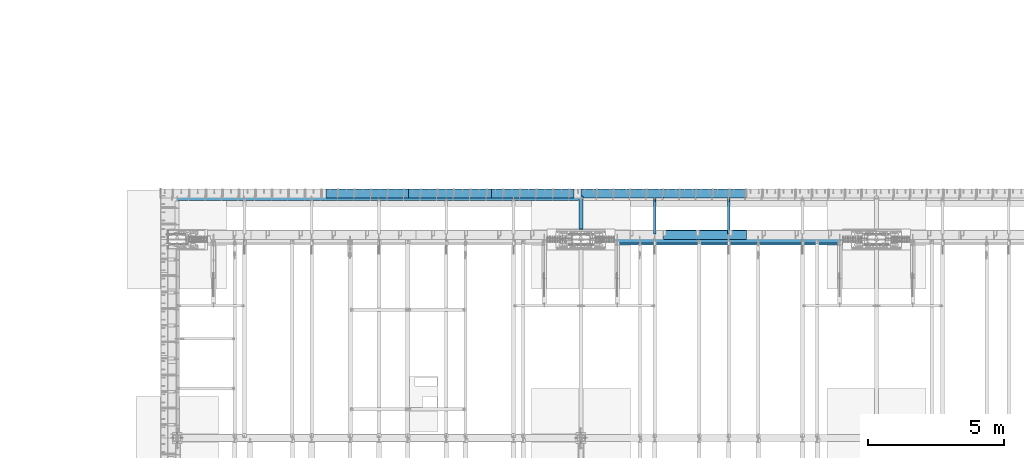
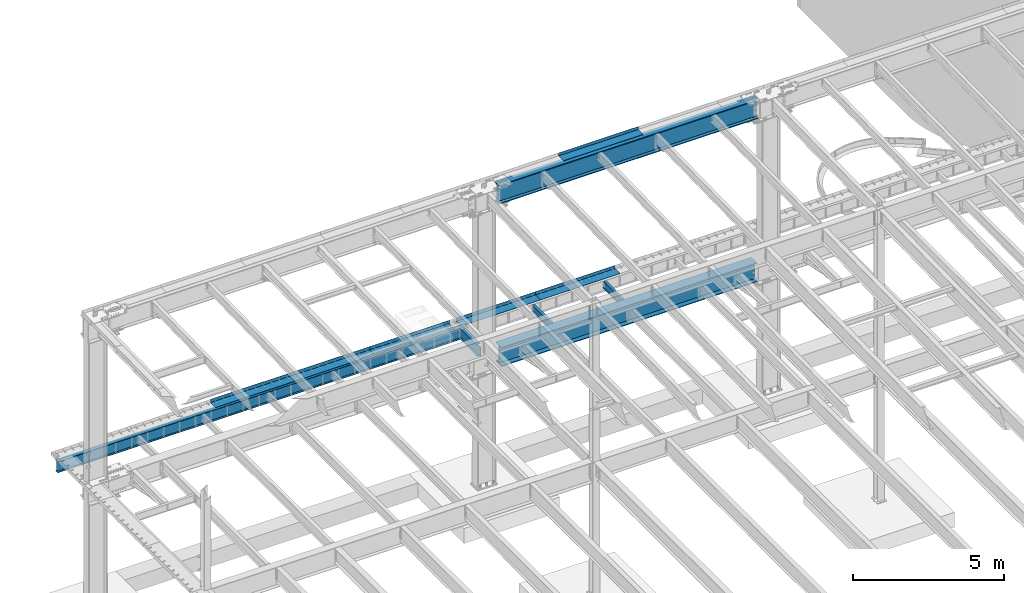
# One storey, part 1130 of 1763: 12 beams, 7 elements without a shape of their own.
"""IFC2X3 building model written with IfcOpenShell, lengths in millimetres."""

from ifc_helpers import new_model, si_unit, frame, origin_with_axes, place, context, subcontext, project, spatial, faceted_brep, material, type_object, element, aggregate, save


model = new_model("IFC2X3")

# Units and contexts
model_context = context("Model", 3, precision=1e-05, world=origin_with_axes())
body_context = subcontext(model_context, "Body", "Model", "MODEL_VIEW")
ifc_project = project(units=[si_unit("LENGTHUNIT", "METRE", prefix="MILLI"), si_unit("AREAUNIT", "SQUARE_METRE"), si_unit("VOLUMEUNIT", "CUBIC_METRE"), si_unit("MASSUNIT", "GRAM", prefix="KILO"), si_unit("TIMEUNIT", "SECOND"), si_unit("PLANEANGLEUNIT", "RADIAN"), si_unit("SOLIDANGLEUNIT", "STERADIAN"), si_unit("THERMODYNAMICTEMPERATUREUNIT", "DEGREE_CELSIUS"), si_unit("LUMINOUSINTENSITYUNIT", "LUMEN")], contexts=[model_context])

# Site, building, storey
site_placement = place(None, origin_with_axes())
site = spatial("IfcSite", under=ifc_project, at=site_placement, CompositionType="ELEMENT")
building_placement = place(site_placement, origin_with_axes())
building = spatial("IfcBuilding", under=site, at=building_placement, Name="Undefined", CompositionType="ELEMENT")
storey_placement = place(building_placement, origin_with_axes())
storey = spatial("IfcBuildingStorey", under=building, at=storey_placement, Name="Undefined", CompositionType="ELEMENT", Elevation=0.0)

# Assembly, beam
assembly_1_placement = place(storey_placement, origin_with_axes())
assembly_1 = element("IfcElementAssembly", 1, at=assembly_1_placement, inside=storey, Name="BEAM", AssemblyPlace="NOTDEFINED", PredefinedType="RIGID_FRAME")
ifc_material_1 = material(Name="STEEL/A36")
beam_type_1 = type_object("IfcBeamType", PredefinedType="NOTDEFINED")
beam_1_placement = place(assembly_1_placement, frame((-67915.8617736983, 52133.5000002128, 11752.2624917654), z_axis=(-1.0, 0.0, 0.0), x_axis=(0.0, 1.0, 0.0)))
beam_1 = element("IfcBeam", 2, at=beam_1_placement, type_object=beam_type_1, material=ifc_material_1, Name="BENT_PLATE", context=body_context, shape_type="Brep", body=[
    faceted_brep([(0.0, -4.76249999999982, -1524.0), (0.0, -4.76249999999982, 1524.0), (0.0, 4.76249999999982, 1524.0), (0.0, 4.76249999999982, -1524.0), (336.549987792969, 4.76250000000073, 1524.0), (336.549987792969, 4.76250000000073, -1524.0), (327.024987792975, -4.76250000000073, -1524.0), (327.024987792967, -4.76250000000073, 1524.00000000001), (336.549987792969, -122.237499999999, 1524.0), (336.549987792969, -122.237499999999, -1524.0), (327.024987792975, -122.237499999999, 1524.0), (327.024987792975, -122.237499999999, -1524.0)], [[[0, 1, 2, 3]], [[3, 2, 4, 5]], [[1, 0, 6, 7]], [[5, 4, 8, 9]], [[4, 2, 1, 7, 10, 8]], [[7, 6, 11, 10]], [[6, 0, 3, 5, 9, 11]], [[10, 11, 9, 8]]]),
])

# Assembly, beams
assembly_2_placement = place(storey_placement, origin_with_axes())
assembly_2 = element("IfcElementAssembly", 3, at=assembly_2_placement, inside=storey, Name="BEAM", AssemblyPlace="NOTDEFINED", PredefinedType="RIGID_FRAME")
beam_type_2 = type_object("IfcBeamType", PredefinedType="NOTDEFINED")
beam_2_placement = place(assembly_2_placement, frame((-67919.0372736984, 53657.5, 5199.0625), z_axis=(1.0, 0.0, 0.0), x_axis=(0.0, 1.0, 0.0)))
beam_2 = element("IfcBeam", 4, at=beam_2_placement, type_object=beam_type_2, material=ifc_material_1, Name="BENT PLATE", context=body_context, shape_type="Brep", body=[
    faceted_brep([(0.0, -4.76249999999982, -1524.0), (0.0, -4.76249999999982, 1524.0), (0.0, 4.76249999999982, 1524.0), (0.0, 4.76249999999982, -1524.0), (327.024987792967, 4.76250000000073, 1524.0), (327.025018310553, 4.76249999999982, -1524.0), (336.550018310547, -4.76249999999982, -1524.0), (336.550018310547, -4.76249999999982, 1524.0), (327.025018310553, 134.937496948242, 1524.0), (327.025018310553, 134.937496948242, -1524.0), (336.550018310547, 134.937496948242, 1524.0), (336.550018310547, 134.937496948242, -1524.0)], [[[0, 1, 2, 3]], [[3, 2, 4, 5]], [[1, 0, 6, 7]], [[5, 4, 8, 9]], [[4, 2, 1, 7, 10, 8]], [[7, 6, 11, 10]], [[6, 0, 3, 5, 9, 11]], [[10, 11, 9, 8]]]),
])
beam_3_placement = place(assembly_2_placement, frame((-70967.0372736984, 53657.5, 5199.0625), z_axis=(1.0, 0.0, 0.0), x_axis=(0.0, 1.0, 0.0)))
beam_3 = element("IfcBeam", 5, at=beam_3_placement, type_object=beam_type_2, material=ifc_material_1, Name="BENT PLATE", context=body_context, shape_type="Brep", body=[
    faceted_brep([(0.0, -4.76249999999982, -1524.0), (0.0, -4.76249999999982, 1524.0), (0.0, 4.76249999999982, 1524.0), (0.0, 4.76249999999982, -1524.0), (327.024987792967, 4.76250000000073, 1524.0), (327.025018310553, 4.76249999999982, -1524.0), (336.550018310547, -4.76249999999982, -1524.0), (336.550018310547, -4.76249999999982, 1524.0), (327.025018310553, 134.937496948242, 1524.0), (327.025018310553, 134.937496948242, -1524.0), (336.550018310547, 134.937496948242, 1524.0), (336.550018310547, 134.937496948242, -1524.0)], [[[0, 1, 2, 3]], [[3, 2, 4, 5]], [[1, 0, 6, 7]], [[5, 4, 8, 9]], [[4, 2, 1, 7, 10, 8]], [[7, 6, 11, 10]], [[6, 0, 3, 5, 9, 11]], [[10, 11, 9, 8]]]),
])
aggregate(assembly_2, [beam_2, beam_3])

assembly_3_placement = place(storey_placement, origin_with_axes())
assembly_3 = element("IfcElementAssembly", 6, at=assembly_3_placement, inside=storey, Name="BEAM", AssemblyPlace="NOTDEFINED", PredefinedType="RIGID_FRAME")
beam_4_placement = place(assembly_3_placement, frame((-74269.0372736984, 53657.5, 5199.0625), z_axis=(1.0, 0.0, 0.0), x_axis=(0.0, 1.0, 0.0)))
beam_4 = element("IfcBeam", 7, at=beam_4_placement, type_object=beam_type_2, material=ifc_material_1, Name="BENT PLATE", context=body_context, shape_type="Brep", body=[
    faceted_brep([(0.0, -4.76249999999982, -1524.0), (0.0, -4.76249999999982, 1524.0), (0.0, 4.76249999999982, 1524.0), (0.0, 4.76249999999982, -1524.0), (327.024987792967, 4.76250000000073, 1524.0), (327.025018310553, 4.76249999999982, -1524.0), (336.550018310547, -4.76249999999982, -1524.0), (336.550018310547, -4.76249999999982, 1524.0), (327.025018310553, 134.937496948242, 1524.0), (327.025018310553, 134.937496948242, -1524.0), (336.550018310547, 134.937496948242, 1524.0), (336.550018310547, 134.937496948242, -1524.0)], [[[0, 1, 2, 3]], [[3, 2, 4, 5]], [[1, 0, 6, 7]], [[5, 4, 8, 9]], [[4, 2, 1, 7, 10, 8]], [[7, 6, 11, 10]], [[6, 0, 3, 5, 9, 11]], [[10, 11, 9, 8]]]),
])
beam_5_placement = place(assembly_3_placement, frame((-77317.0372736984, 53657.5, 5199.0625), z_axis=(1.0, 0.0, 0.0), x_axis=(0.0, 1.0, 0.0)))
beam_5 = element("IfcBeam", 8, at=beam_5_placement, type_object=beam_type_2, material=ifc_material_1, Name="BENT PLATE", context=body_context, shape_type="Brep", body=[
    faceted_brep([(0.0, -4.76249999999982, -1524.0), (0.0, -4.76249999999982, 1524.0), (0.0, 4.76249999999982, 1524.0), (0.0, 4.76249999999982, -1524.0), (327.024987792967, 4.76250000000073, 1524.0), (327.025018310553, 4.76249999999982, -1524.0), (336.550018310547, -4.76249999999982, -1524.0), (336.550018310547, -4.76249999999982, 1524.0), (327.025018310553, 134.937496948242, 1524.0), (327.025018310553, 134.937496948242, -1524.0), (336.550018310547, 134.937496948242, 1524.0), (336.550018310547, 134.937496948242, -1524.0)], [[[0, 1, 2, 3]], [[3, 2, 4, 5]], [[1, 0, 6, 7]], [[5, 4, 8, 9]], [[4, 2, 1, 7, 10, 8]], [[7, 6, 11, 10]], [[6, 0, 3, 5, 9, 11]], [[10, 11, 9, 8]]]),
])
beam_6_placement = place(assembly_3_placement, frame((-80365.0372736984, 53657.5, 5199.0625), z_axis=(1.0, 0.0, 0.0), x_axis=(0.0, 1.0, 0.0)))
beam_6 = element("IfcBeam", 9, at=beam_6_placement, type_object=beam_type_2, material=ifc_material_1, Name="BENT PLATE", context=body_context, shape_type="Brep", body=[
    faceted_brep([(0.0, -4.76249999999982, -1524.0), (0.0, -4.76249999999982, 1524.0), (0.0, 4.76249999999982, 1524.0), (0.0, 4.76249999999982, -1524.0), (327.024987792967, 4.76250000000073, 1524.0), (327.025018310553, 4.76249999999982, -1524.0), (336.550018310547, -4.76249999999982, -1524.0), (336.550018310547, -4.76249999999982, 1524.0), (327.025018310553, 134.937496948242, 1524.0), (327.025018310553, 134.937496948242, -1524.0), (336.550018310547, 134.937496948242, 1524.0), (336.550018310547, 134.937496948242, -1524.0)], [[[0, 1, 2, 3]], [[3, 2, 4, 5]], [[1, 0, 6, 7]], [[5, 4, 8, 9]], [[4, 2, 1, 7, 10, 8]], [[7, 6, 11, 10]], [[6, 0, 3, 5, 9, 11]], [[10, 11, 9, 8]]]),
])

# Assembly, beam
assembly_4_placement = place(storey_placement, origin_with_axes())
assembly_4 = element("IfcElementAssembly", 10, at=assembly_4_placement, inside=storey, Name="BEAM", AssemblyPlace="NOTDEFINED", PredefinedType="RIGID_FRAME")
ifc_material_2 = material(Name="STEEL/A992")
beam_type_3 = type_object("IfcBeamType", Name="W12X16", PredefinedType="NOTDEFINED")
beam_7_placement = place(assembly_4_placement, frame((-67042.7372736984, 52120.8, 5041.9), z_axis=(0.0, 0.0, 1.0), x_axis=(0.0, 1.0, 0.0)))
beam_7 = element("IfcBeam", 11, at=beam_7_placement, type_object=beam_type_3, material=ifc_material_2, Name="BEAM", ObjectType="W12X16", context=body_context, shape_type="Brep", body=[
    faceted_brep([(20.6374999999971, -3.17500000000291, -114.3), (20.6374999999971, 3.17500000000291, -114.3), (192.087500190733, 3.17500000000291, -114.3), (192.087500190733, -3.17500000000291, -114.3), (196.94757970878, 3.17500000000291, -115.266729922588), (196.94757970878, -3.17500000000291, -115.266729922588), (201.067756176933, 3.17500000000291, -118.019743823066), (201.067756176933, -3.17500000000291, -118.019743823066), (203.820770077407, 3.17500000000291, -122.13992029122), (203.820770077407, -3.17500000000291, -122.13992029122), (204.787499999999, -3.17500000000291, -126.999999809265), (204.787499999999, 3.17500000000291, -126.999999809265), (204.787499999999, 3.17500000000291, -146.05), (204.787499999999, 50.8000000000029, -146.05), (204.787499999999, 50.8000000000029, -152.4), (204.787499999999, -50.8000000000029, -152.4), (204.787499999999, -50.8000000000029, -146.05), (204.787499999999, -3.17500000000291, -146.05), (1431.13125000001, 50.8000000000029, 146.05), (1431.13125000001, 3.17500000000291, 146.05), (204.787499999999, 3.17500000000291, 146.05), (204.787499999999, 50.8000000000029, 146.05), (192.087500190733, -3.17500000000291, 114.3), (192.087500190733, 3.17500000000291, 114.3), (20.6374999999971, 3.17500000000291, 114.3), (20.6374999999971, -3.17500000000291, 114.3), (196.94757970878, -3.17500000000291, 115.266729922588), (196.94757970878, 3.17500000000291, 115.266729922588), (201.067756176933, -3.17500000000291, 118.019743823066), (201.067756176933, 3.17500000000291, 118.019743823066), (203.820770077407, -3.17500000000291, 122.13992029122), (203.820770077407, 3.17500000000291, 122.13992029122), (204.787499999999, -3.17500000000291, 126.999999809265), (204.787499999999, 3.17500000000291, 126.999999809265), (1431.13125000001, -50.8000000000029, 152.4), (1431.13125000001, 50.8000000000029, 152.4), (204.787499999999, 50.8000000000029, 152.4), (204.787499999999, -50.8000000000029, 152.4), (1431.13125000001, -50.8000000000029, 146.05), (204.787499999999, -50.8000000000029, 146.05), (1431.13125000001, -3.17500000000291, 146.05), (204.787499999999, -3.17500000000291, 146.05), (1431.13125000001, -3.17500000000291, 139.440001487732), (1431.13125000001, 3.17500000000291, 139.440001487732), (1432.0979799226, -3.17500000000291, 134.579921969686), (1432.0979799226, 3.17500000000291, 134.579921969686), (1434.85099382307, -3.17500000000291, 130.459745501533), (1434.85099382307, 3.17500000000291, 130.459745501533), (1438.97117029122, -3.17500000000291, 127.706731601054), (1438.97117029122, 3.17500000000291, 127.706731601054), (1443.83124980927, -3.17500000000291, 126.740001678467), (1443.83124980927, 3.17500000000291, 126.740001678467), (1507.33125, -3.17500000000291, 126.740001678467), (1507.33125, 3.17500000000291, 126.740001678467), (1507.33125, -3.17500000000291, -146.05), (1507.33125, -50.8000000000029, -146.05), (1507.33125, -50.8000000000029, -152.4), (1507.33125, 50.8000000000029, -152.4), (1507.33125, 50.8000000000029, -146.05), (1507.33125, 3.17500000000291, -146.05)], [[[0, 1, 2, 3]], [[3, 2, 4, 5]], [[5, 4, 6, 7]], [[7, 6, 8, 9]], [[10, 11, 12, 13, 14, 15, 16, 17]], [[9, 8, 11, 10]], [[18, 19, 20, 21]], [[22, 23, 24, 25]], [[26, 27, 23, 22]], [[28, 29, 27, 26]], [[30, 31, 29, 28]], [[32, 33, 31, 30]], [[34, 35, 36, 37]], [[38, 34, 37, 39]], [[40, 38, 39, 41]], [[37, 36, 21, 20, 33, 32, 41, 39]], [[35, 18, 21, 36]], [[34, 38, 40, 42, 43, 19, 18, 35]], [[44, 45, 43, 42]], [[46, 47, 45, 44]], [[48, 49, 47, 46]], [[50, 51, 49, 48]], [[52, 53, 51, 50]], [[54, 55, 56, 57, 58, 59, 53, 52]], [[55, 54, 17, 16]], [[56, 55, 16, 15]], [[57, 56, 15, 14]], [[58, 57, 14, 13]], [[59, 58, 13, 12]], [[6, 4, 2, 1, 24, 23, 27, 29, 31, 33, 20, 19, 43, 45, 47, 49, 51, 53, 59, 12, 11, 8]], [[25, 24, 1, 0]], [[54, 52, 50, 48, 46, 44, 42, 40, 41, 32, 30, 28, 26, 22, 25, 0, 3, 5, 7, 9, 10, 17]]]),
])
aggregate(assembly_4, [beam_7])

assembly_5_placement = place(storey_placement, origin_with_axes())
assembly_5 = element("IfcElementAssembly", 12, at=assembly_5_placement, inside=storey, Name="BEAM", AssemblyPlace="NOTDEFINED", PredefinedType="RIGID_FRAME")
beam_8_placement = place(assembly_5_placement, frame((-69766.8872736983, 52120.8, 5041.9), z_axis=(0.0, 0.0, 1.0), x_axis=(0.0, 1.0, 0.0)))
beam_8 = element("IfcBeam", 13, at=beam_8_placement, type_object=beam_type_3, material=ifc_material_2, Name="BEAM", ObjectType="W12X16", context=body_context, shape_type="Brep", body=[
    faceted_brep([(20.6374999999971, -3.17500000000291, -114.3), (20.6374999999971, 3.17500000000291, -114.3), (192.087500190733, 3.17500000000291, -114.3), (192.087500190733, -3.17500000000291, -114.3), (196.94757970878, 3.17500000000291, -115.266729922588), (196.94757970878, -3.17500000000291, -115.266729922588), (201.067756176933, 3.17500000000291, -118.019743823066), (201.067756176933, -3.17500000000291, -118.019743823066), (203.820770077407, 3.17500000000291, -122.13992029122), (203.820770077407, -3.17500000000291, -122.13992029122), (204.787499999999, -3.17500000000291, -126.999999809265), (204.787499999999, 3.17500000000291, -126.999999809265), (204.787499999999, 3.17500000000291, -146.05), (204.787499999999, 50.8000000000029, -146.05), (204.787499999999, 50.8000000000029, -152.4), (204.787499999999, -50.8000000000029, -152.4), (204.787499999999, -50.8000000000029, -146.05), (204.787499999999, -3.17500000000291, -146.05), (1431.13125000001, 50.8000000000029, 146.05), (1431.13125000001, 3.17500000000291, 146.05), (204.787499999999, 3.17500000000291, 146.05), (204.787499999999, 50.8000000000029, 146.05), (192.087500190733, -3.17500000000291, 114.3), (192.087500190733, 3.17500000000291, 114.3), (20.6374999999971, 3.17500000000291, 114.3), (20.6374999999971, -3.17500000000291, 114.3), (196.94757970878, -3.17500000000291, 115.266729922588), (196.94757970878, 3.17500000000291, 115.266729922588), (201.067756176933, -3.17500000000291, 118.019743823066), (201.067756176933, 3.17500000000291, 118.019743823066), (203.820770077407, -3.17500000000291, 122.13992029122), (203.820770077407, 3.17500000000291, 122.13992029122), (204.787499999999, -3.17500000000291, 126.999999809265), (204.787499999999, 3.17500000000291, 126.999999809265), (1431.13125000001, -50.8000000000029, 152.4), (1431.13125000001, 50.8000000000029, 152.4), (204.787499999999, 50.8000000000029, 152.4), (204.787499999999, -50.8000000000029, 152.4), (1431.13125000001, -50.8000000000029, 146.05), (204.787499999999, -50.8000000000029, 146.05), (1431.13125000001, -3.17500000000291, 146.05), (204.787499999999, -3.17500000000291, 146.05), (1431.13125000001, -3.17500000000291, 139.440001487732), (1431.13125000001, 3.17500000000291, 139.440001487732), (1432.0979799226, -3.17500000000291, 134.579921969686), (1432.0979799226, 3.17500000000291, 134.579921969686), (1434.85099382307, -3.17500000000291, 130.459745501533), (1434.85099382307, 3.17500000000291, 130.459745501533), (1438.97117029122, -3.17500000000291, 127.706731601054), (1438.97117029122, 3.17500000000291, 127.706731601054), (1443.83124980927, -3.17500000000291, 126.740001678467), (1443.83124980927, 3.17500000000291, 126.740001678467), (1507.33125, -3.17500000000291, 126.740001678467), (1507.33125, 3.17500000000291, 126.740001678467), (1507.33125, -3.17500000000291, -146.05), (1507.33125, -50.8000000000029, -146.05), (1507.33125, -50.8000000000029, -152.4), (1507.33125, 50.8000000000029, -152.4), (1507.33125, 50.8000000000029, -146.05), (1507.33125, 3.17500000000291, -146.05)], [[[0, 1, 2, 3]], [[3, 2, 4, 5]], [[5, 4, 6, 7]], [[7, 6, 8, 9]], [[10, 11, 12, 13, 14, 15, 16, 17]], [[9, 8, 11, 10]], [[18, 19, 20, 21]], [[22, 23, 24, 25]], [[26, 27, 23, 22]], [[28, 29, 27, 26]], [[30, 31, 29, 28]], [[32, 33, 31, 30]], [[34, 35, 36, 37]], [[38, 34, 37, 39]], [[40, 38, 39, 41]], [[37, 36, 21, 20, 33, 32, 41, 39]], [[35, 18, 21, 36]], [[34, 38, 40, 42, 43, 19, 18, 35]], [[44, 45, 43, 42]], [[46, 47, 45, 44]], [[48, 49, 47, 46]], [[50, 51, 49, 48]], [[52, 53, 51, 50]], [[54, 55, 56, 57, 58, 59, 53, 52]], [[55, 54, 17, 16]], [[56, 55, 16, 15]], [[57, 56, 15, 14]], [[58, 57, 14, 13]], [[59, 58, 13, 12]], [[6, 4, 2, 1, 24, 23, 27, 29, 31, 33, 20, 19, 43, 45, 47, 49, 51, 53, 59, 12, 11, 8]], [[25, 24, 1, 0]], [[54, 52, 50, 48, 46, 44, 42, 40, 41, 32, 30, 28, 26, 22, 25, 0, 3, 5, 7, 9, 10, 17]]]),
])
aggregate(assembly_5, [beam_8])

assembly_6_placement = place(storey_placement, origin_with_axes())
assembly_6 = element("IfcElementAssembly", 14, at=assembly_6_placement, inside=storey, Name="BEAM", AssemblyPlace="NOTDEFINED", PredefinedType="RIGID_FRAME")
beam_type_4 = type_object("IfcBeamType", Name="W18X40", PredefinedType="NOTDEFINED")
beam_9_placement = place(assembly_6_placement, frame((-72491.0372736984, 52120.8, 4967.2875), z_axis=(0.0, 0.0, 1.0), x_axis=(0.0, 1.0, 0.0)))
beam_9 = element("IfcBeam", 15, at=beam_9_placement, type_object=beam_type_4, material=ifc_material_2, Name="BEAM", ObjectType="W18X40", context=body_context, shape_type="Brep", body=[
    faceted_brep([(385.15757393559, -76.1999999999971, 227.0125), (385.15757393559, 76.1999999999971, 227.0125), (377.825012672634, 76.1999999999971, 214.3125), (377.825012672634, 3.96875, 214.3125), (377.595797451308, 3.96875, 213.91549911499), (377.595797451308, -3.96875, 213.91549911499), (377.825012672634, -3.96875, 214.3125), (377.825012672634, -76.1999999999971, 214.3125), (403.224996948229, -3.96875, 213.91549911499), (403.224996948229, 3.96875, 213.91549911499), (424.434101018858, 3.96875, 204.211830867132), (424.434101018858, -3.96875, 204.211830867132), (427.472016714142, 3.96875, 201.276913128712), (427.472016714142, -3.96875, 201.276913128712), (427.996621366721, 3.96875, 197.085557278698), (427.996621366721, -3.96875, 197.085557278698), (425.775777831688, 3.96875, 193.492434974088), (425.775777831688, -3.96875, 193.492434974088), (421.792207621249, 3.96875, 192.0875), (421.792207621249, -3.96875, 192.0875), (225.424999999988, 3.96875, 192.0875), (225.424999999988, -3.96875, 192.0875), (225.424999999988, 3.96875, -192.0875), (225.424999999988, -3.96875, -192.0875), (334.333211039215, 3.96875, -192.0875), (334.333211039215, -3.96875, -192.0875), (338.316781249654, 3.96875, -193.492434974089), (338.316781249654, -3.96875, -193.492434974089), (340.537624784687, 3.96875, -197.085557278698), (340.537624784687, -3.96875, -197.085557278698), (340.013020132108, 3.96875, -201.276913128712), (340.013020132108, -3.96875, -201.276913128712), (336.975104436824, 3.96875, -204.211830867132), (336.975104436824, -3.96875, -204.211830867132), (315.766000366195, 3.96875, -213.91549911499), (315.766000366195, -3.96875, -213.91549911499), (1600.2, 3.96875, -214.3125), (1600.2, 76.1999999999971, -214.3125), (315.307591212309, 76.1999999999971, -214.3125), (315.307591212309, 3.96875, -214.3125), (1600.2, 76.1999999999971, -227.0125), (1600.2, -76.1999999999971, -227.0125), (307.975402928918, -76.1999999999971, -227.0125), (307.975402928918, 76.1999999999971, -227.0125), (1600.2, -76.1999999999971, -214.3125), (315.307591212309, -76.1999999999971, -214.3125), (1600.2, -3.96875, -214.3125), (315.307591212309, -3.96875, -214.3125), (1600.2, 3.96875, 214.3125), (1600.2, 76.1999999999971, 214.3125), (1600.2, 76.1999999999971, 227.0125), (1600.2, -76.1999999999971, 227.0125), (1600.2, -76.1999999999971, 214.3125), (1600.2, -3.96875, 214.3125)], [[[0, 1, 2, 3, 4, 5, 6, 7]], [[8, 9, 10, 11]], [[11, 10, 12, 13]], [[13, 12, 14, 15]], [[15, 14, 16, 17]], [[17, 16, 18, 19]], [[19, 18, 20, 21]], [[21, 20, 22, 23]], [[24, 25, 23, 22]], [[25, 24, 26, 27]], [[27, 26, 28, 29]], [[29, 28, 30, 31]], [[31, 30, 32, 33]], [[33, 32, 34, 35]], [[36, 37, 38, 39]], [[40, 41, 42, 43]], [[41, 44, 45, 42]], [[44, 46, 47, 45]], [[35, 34, 39, 38, 43, 42, 45, 47]], [[37, 40, 43, 38]], [[36, 48, 49, 50, 51, 52, 53, 46, 44, 41, 40, 37]], [[52, 51, 0, 7]], [[53, 52, 7, 6]], [[8, 11, 13, 15, 17, 19, 21, 23, 25, 27, 29, 31, 33, 35, 47, 46, 53, 6, 5]], [[9, 8, 5, 4]], [[48, 36, 39, 34, 32, 30, 28, 26, 24, 22, 20, 18, 16, 14, 12, 10, 9, 4, 3]], [[49, 48, 3, 2]], [[50, 49, 2, 1]], [[51, 50, 1, 0]]]),
])
aggregate(assembly_6, [beam_9])

# Beam
beam_10_placement = place(assembly_3_placement, frame((-87985.0372736984, 53644.8, 4967.2875), z_axis=(0.0, 0.0, 1.0), x_axis=(1.0, 0.0, 0.0)))
beam_10 = element("IfcBeam", 16, at=beam_10_placement, type_object=beam_type_4, material=ifc_material_2, Name="BEAM", ObjectType="W18X40", context=body_context, shape_type="Brep", body=[
    faceted_brep([(15404.30625, -3.96875, -214.3125), (15404.30625, -76.1999999999971, -214.3125), (15404.30625, -76.1999999999971, -227.0125), (15404.30625, 76.1999999999971, -227.0125), (15404.30625, 76.1999999999971, -214.3125), (15404.30625, 3.96875, -214.3125), (15404.30625, 3.96875, -208.222499809265), (15404.30625, -3.96875, -208.222499809265), (15405.2729799226, 3.96875, -203.36242029122), (15405.2729799226, -3.96875, -203.36242029122), (15408.0259938231, 3.96875, -199.242243823066), (15408.0259938231, -3.96875, -199.242243823066), (15412.1461702912, 3.96875, -196.489229922588), (15412.1461702912, -3.96875, -196.489229922588), (15417.0062498093, 3.96875, -195.5225), (15417.0062498093, -3.96875, -195.5225), (15477.33125, -3.96875, -195.5225), (15477.33125, 3.96875, -195.5225), (-3.20142135024071e-10, 3.96874999856664, 214.312499999993), (-1.89174897968769e-10, 76.1999999984982, 214.312500000009), (15404.30625, 76.1999999999971, 214.3125), (15404.30625, 3.96875, 214.3125), (1.89174897968769e-10, -76.1999999984182, -227.012500000012), (1.74622982740402e-10, -76.1999999985128, -214.312500000011), (3.20142135024071e-10, -3.96874999858119, -214.312499999995), (-3.34694050252438e-10, -3.96875000142609, 214.312499999991), (-4.80213202536106e-10, -76.2000000013722, 214.312499999973), (-5.0931703299284e-10, -76.200000001445, 227.012499999972), (-1.89174897968769e-10, 76.1999999984109, 227.01250000001), (3.34694050252438e-10, 3.96875000140426, -214.312499999991), (4.80213202536106e-10, 76.2000000013577, -214.312499999975), (4.94765117764473e-10, 76.2000000014305, -227.012499999973), (15404.30625, -3.96875, 214.3125), (15404.30625, -76.1999999999971, 214.3125), (15404.30625, -76.1999999999971, 227.0125), (15404.30625, 76.1999999999971, 227.0125), (15404.30625, -3.96875, 207.702501487732), (15404.30625, 3.96875, 207.702501487732), (15405.2729799226, -3.96875, 202.842421969686), (15405.2729799226, 3.96875, 202.842421969686), (15408.0259938231, -3.96875, 198.722245501533), (15408.0259938231, 3.96875, 198.722245501533), (15412.1461702912, -3.96875, 195.969231601054), (15412.1461702912, 3.96875, 195.969231601054), (15417.0062498093, -3.96875, 195.002501678467), (15417.0062498093, 3.96875, 195.002501678467), (15477.33125, -3.96875, 195.002501678467), (15477.33125, 3.96875, 195.002501678467)], [[[0, 1, 2, 3, 4, 5, 6, 7]], [[7, 6, 8, 9]], [[9, 8, 10, 11]], [[11, 10, 12, 13]], [[13, 12, 14, 15]], [[16, 15, 14, 17]], [[18, 19, 20, 21]], [[22, 23, 24, 25, 26, 27, 28, 19, 18, 29, 30, 31]], [[26, 25, 32, 33]], [[27, 26, 33, 34]], [[28, 27, 34, 35]], [[19, 28, 35, 20]], [[34, 33, 32, 36, 37, 21, 20, 35]], [[38, 39, 37, 36]], [[40, 41, 39, 38]], [[42, 43, 41, 40]], [[44, 45, 43, 42]], [[46, 47, 45, 44]], [[47, 46, 16, 17]], [[12, 10, 8, 6, 5, 29, 18, 21, 37, 39, 41, 43, 45, 47, 17, 14]], [[30, 29, 5, 4]], [[31, 30, 4, 3]], [[22, 31, 3, 2]], [[23, 22, 2, 1]], [[24, 23, 1, 0]], [[46, 44, 42, 40, 38, 36, 32, 25, 24, 0, 7, 9, 11, 13, 15, 16]]]),
])

aggregate(assembly_3, [beam_4, beam_5, beam_6, beam_10])

# Assembly, beam
assembly_7_placement = place(storey_placement, origin_with_axes())
assembly_7 = element("IfcElementAssembly", 17, at=assembly_7_placement, inside=storey, Name="BEAM", AssemblyPlace="NOTDEFINED", PredefinedType="RIGID_FRAME")
beam_type_5 = type_object("IfcBeamType", Name="W30X173", PredefinedType="NOTDEFINED")
beam_11_placement = place(assembly_7_placement, frame((-72491.0372736984, 52120.8, 4806.95), z_axis=(0.0, 0.0, 1.0), x_axis=(1.0, 0.0, 0.0)))
beam_11 = element("IfcBeam", 18, at=beam_11_placement, type_object=beam_type_5, material=ifc_material_2, Name="BEAM", ObjectType="W30X173", context=body_context, shape_type="Brep", body=[
    faceted_brep([(557.212499999994, 41.2750003814726, -360.3625), (557.212499999994, 41.2750003814726, -387.35), (695.324999809258, 41.2750003814726, -387.35), (695.324999809258, 41.2750003814726, -360.3625), (699.577569524408, 40.4291116719833, -387.35), (699.577569524408, 40.4291116719833, -360.3625), (703.182724050064, 38.0202244315442, -387.35), (703.182724050064, 38.0202244315442, -360.3625), (705.591611290503, 34.4150699058882, -387.35), (705.591611290503, 34.4150699058882, -360.3625), (695.324999809258, 19.0500000000029, -360.3625), (695.324999809258, 19.0500000000029, -387.35), (557.212499999994, 19.0500000000029, -387.35), (557.212499999994, 19.0500000000029, -360.3625), (699.577569524408, 19.8958887094923, -360.3625), (699.577569524408, 19.8958887094923, -387.35), (703.182724050064, 22.3047759499314, -360.3625), (703.182724050064, 22.3047759499314, -387.35), (705.591611290503, 25.9099304755873, -360.3625), (705.591611290503, 25.9099304755873, -387.35), (706.437499999993, 30.1625001907378, -360.3625), (706.437499999993, 30.1625001907378, -387.35), (557.212499999994, 7.9375, 360.3625), (557.212499999994, 190.5, 360.3625), (10339.3875, 190.5, 360.3625), (10339.3875, 7.9375, 360.3625), (557.212499999994, 190.5, 387.35), (10339.3875, 190.5, 387.35), (557.212499999994, -190.5, 387.35), (10339.3875, -190.5, 387.35), (557.212499999994, -190.5, 360.3625), (10339.3875, -190.5, 360.3625), (557.212499999994, -7.9375, 360.3625), (10339.3875, -7.9375, 360.3625), (557.212499999994, -7.9375, -360.3625), (10339.3875, -7.9375, -360.3625), (557.212499999994, -190.5, -360.3625), (10339.3875, -190.5, -360.3625), (557.212499999994, -190.5, -387.35), (10339.3875, -190.5, -387.35), (557.212499999994, 190.5, -387.35), (557.212499999994, 190.5, -360.3625), (10339.3875, 190.5, -360.3625), (10339.3875, 190.5, -387.35), (10339.3875, 41.2750003814726, -360.3625), (10339.3875, 41.2750003814726, -387.35), (10201.2750001907, 41.2750003814726, -360.3625), (10201.2750001907, 41.2750003814726, -387.35), (10197.0224304756, 40.4291116719833, -360.3625), (10197.0224304756, 40.4291116719833, -387.35), (10193.4172759499, 38.0202244315442, -360.3625), (10193.4172759499, 38.0202244315442, -387.35), (10191.0083887095, 34.4150699058882, -360.3625), (10191.0083887095, 34.4150699058882, -387.35), (10190.1625, 30.1625001907378, -360.3625), (10190.1625, 30.1625001907378, -387.35), (10191.0083887095, 25.9099304755873, -360.3625), (10191.0083887095, 25.9099304755873, -387.35), (10193.4172759499, 22.3047759499314, -360.3625), (10193.4172759499, 22.3047759499314, -387.35), (10197.0224304756, 19.8958887094923, -360.3625), (10197.0224304756, 19.8958887094923, -387.35), (10201.2750001907, 19.0500000000029, -360.3625), (10201.2750001907, 19.0500000000029, -387.35), (10339.3875, 19.0500000000029, -360.3625), (10339.3875, 19.0500000000029, -387.35), (10339.3875, 7.9375, -360.3625), (557.212499999994, 7.9375, -360.3625)], [[[0, 1, 2, 3]], [[3, 2, 4, 5]], [[5, 4, 6, 7]], [[7, 6, 8, 9]], [[10, 11, 12, 13]], [[14, 15, 11, 10]], [[16, 17, 15, 14]], [[18, 19, 17, 16]], [[20, 21, 19, 18]], [[9, 8, 21, 20]], [[22, 23, 24, 25]], [[23, 26, 27, 24]], [[26, 28, 29, 27]], [[28, 30, 31, 29]], [[30, 32, 33, 31]], [[32, 34, 35, 33]], [[34, 36, 37, 35]], [[36, 38, 39, 37]], [[40, 41, 42, 43]], [[43, 42, 44, 45]], [[44, 46, 47, 45]], [[48, 49, 47, 46]], [[50, 51, 49, 48]], [[52, 53, 51, 50]], [[54, 55, 53, 52]], [[56, 57, 55, 54]], [[58, 59, 57, 56]], [[60, 61, 59, 58]], [[62, 63, 61, 60]], [[64, 65, 63, 62]], [[66, 25, 24, 27, 29, 31, 33, 35, 37, 39, 65, 64]], [[67, 22, 25, 66]], [[38, 36, 34, 32, 30, 28, 26, 23, 22, 67, 13, 12]], [[6, 4, 2, 1, 40, 43, 45, 47, 49, 51, 53, 55, 57, 59, 61, 63, 65, 39, 38, 12, 11, 15, 17, 19, 21, 8]], [[41, 40, 1, 0]], [[16, 14, 10, 13, 67, 66, 64, 62, 60, 58, 56, 54, 52, 50, 48, 46, 44, 42, 41, 0, 3, 5, 7, 9, 20, 18]]]),
])
aggregate(assembly_7, [beam_11])

# Beam
beam_type_6 = type_object("IfcBeamType", Name="W30X148", PredefinedType="NOTDEFINED")
beam_12_placement = place(assembly_1_placement, frame((-72491.0372736984, 52120.8000002128, 11358.5624917654), z_axis=(0.0, 0.0, 1.0), x_axis=(1.0, 0.0, 0.0)))
beam_12 = element("IfcBeam", 19, at=beam_12_placement, type_object=beam_type_6, material=ifc_material_2, Name="BEAM", ObjectType="W30X148", context=body_context, shape_type="Brep", body=[
    faceted_brep([(10415.5875, -19.0500000000029, -358.775), (10274.3000001907, -19.0500000000029, -358.775), (10274.3000001907, -19.0500000000029, -388.9375), (10415.5875, -19.0500000000029, -388.9375), (10270.0474304756, -19.8958887094923, -358.775), (10270.0474304756, -19.8958887094923, -388.9375), (10266.4422759499, -22.3047759499314, -358.775), (10266.4422759499, -22.3047759499314, -388.9375), (10264.0333887095, -25.9099304755873, -358.775), (10264.0333887095, -25.9099304755873, -388.9375), (10263.1875, -30.1625001907378, -358.775), (10263.1875, -30.1625001907378, -388.9375), (10264.0333887095, -34.4150699058882, -358.775), (10264.0333887095, -34.4150699058882, -388.9375), (10266.4422759499, -38.0202244315442, -358.775), (10266.4422759499, -38.0202244315442, -388.9375), (10270.0474304756, -40.4291116719833, -358.775), (10270.0474304756, -40.4291116719833, -388.9375), (10274.3000001907, -41.2750003814726, -358.775), (10274.3000001907, -41.2750003814726, -388.9375), (10415.5875, -41.2750003814726, -358.775), (10415.5875, -41.2750003814726, -388.9375), (481.012500000012, -7.9375, 358.775), (481.012500000012, -7.9375, -358.775), (10415.5875, -7.9375, -358.775), (10415.5875, -7.9375, 358.775), (481.012500000012, -133.349999999999, 358.775), (10415.5875, -133.349999999999, 358.775), (481.012500000012, -133.349999999999, 388.9375), (10415.5875, -133.349999999999, 388.9375), (481.012500000012, 133.349999999999, 388.9375), (10415.5875, 133.349999999999, 388.9375), (481.012500000012, 133.349999999999, 358.775), (10415.5875, 133.349999999999, 358.775), (481.012500000012, 7.9375, 358.775), (10415.5875, 7.9375, 358.775), (481.012500000012, 7.9375, -358.775), (10415.5875, 7.9375, -358.775), (481.012500000012, 133.349999999999, -358.775), (10415.5875, 133.349999999999, -358.775), (481.012500000012, 133.349999999999, -388.9375), (10415.5875, 133.349999999999, -388.9375), (481.012500000012, -19.0500000000102, -388.9375), (481.012500000012, -19.0500000000102, -358.775), (622.299999809271, -19.0500000000102, -388.9375), (622.299999809271, -19.0500000000102, -358.775), (626.552569524421, -19.8958887094996, -388.9375), (626.552569524421, -19.8958887094996, -358.775), (630.157724050077, -22.3047759499386, -388.9375), (630.157724050077, -22.3047759499386, -358.775), (632.566611290516, -25.9099304755946, -388.9375), (632.566611290516, -25.9099304755946, -358.775), (633.412500000006, -30.162500190745, -388.9375), (633.412500000006, -30.162500190745, -358.775), (632.566611290516, -34.4150699058955, -388.9375), (632.566611290516, -34.4150699058955, -358.775), (630.157724050077, -38.0202244315515, -388.9375), (630.157724050077, -38.0202244315515, -358.775), (626.552569524421, -40.4291116719905, -388.9375), (626.552569524421, -40.4291116719905, -358.775), (622.299999809271, -41.2750003814799, -388.9375), (622.299999809271, -41.2750003814799, -358.775), (481.012500000012, -41.2750003814799, -388.9375), (481.012500000012, -41.2750003814799, -358.775), (481.012500000012, -133.349999999999, -388.9375), (481.012500000012, -133.349999999999, -358.775), (10415.5875, -133.349999999999, -388.9375), (10415.5875, -133.349999999999, -358.775)], [[[0, 1, 2, 3]], [[4, 5, 2, 1]], [[6, 7, 5, 4]], [[8, 9, 7, 6]], [[10, 11, 9, 8]], [[12, 13, 11, 10]], [[14, 15, 13, 12]], [[16, 17, 15, 14]], [[18, 19, 17, 16]], [[20, 21, 19, 18]], [[22, 23, 24, 25]], [[26, 22, 25, 27]], [[28, 26, 27, 29]], [[30, 28, 29, 31]], [[32, 30, 31, 33]], [[34, 32, 33, 35]], [[36, 34, 35, 37]], [[38, 36, 37, 39]], [[40, 38, 39, 41]], [[23, 22, 26, 28, 30, 32, 34, 36, 38, 40, 42, 43]], [[43, 42, 44, 45]], [[45, 44, 46, 47]], [[47, 46, 48, 49]], [[49, 48, 50, 51]], [[51, 50, 52, 53]], [[53, 52, 54, 55]], [[55, 54, 56, 57]], [[57, 56, 58, 59]], [[59, 58, 60, 61]], [[61, 60, 62, 63]], [[64, 65, 63, 62]], [[65, 64, 66, 67]], [[16, 14, 12, 10, 8, 6, 4, 1, 0, 24, 23, 43, 45, 47, 49, 51, 53, 55, 57, 59, 61, 63, 65, 67, 20, 18]], [[41, 39, 37, 35, 33, 31, 29, 27, 25, 24, 0, 3]], [[66, 64, 62, 60, 58, 56, 54, 52, 50, 48, 46, 44, 42, 40, 41, 3, 2, 5, 7, 9, 11, 13, 15, 17, 19, 21]], [[67, 66, 21, 20]]]),
])

aggregate(assembly_1, [beam_1, beam_12])

save(model, "model.ifc")
